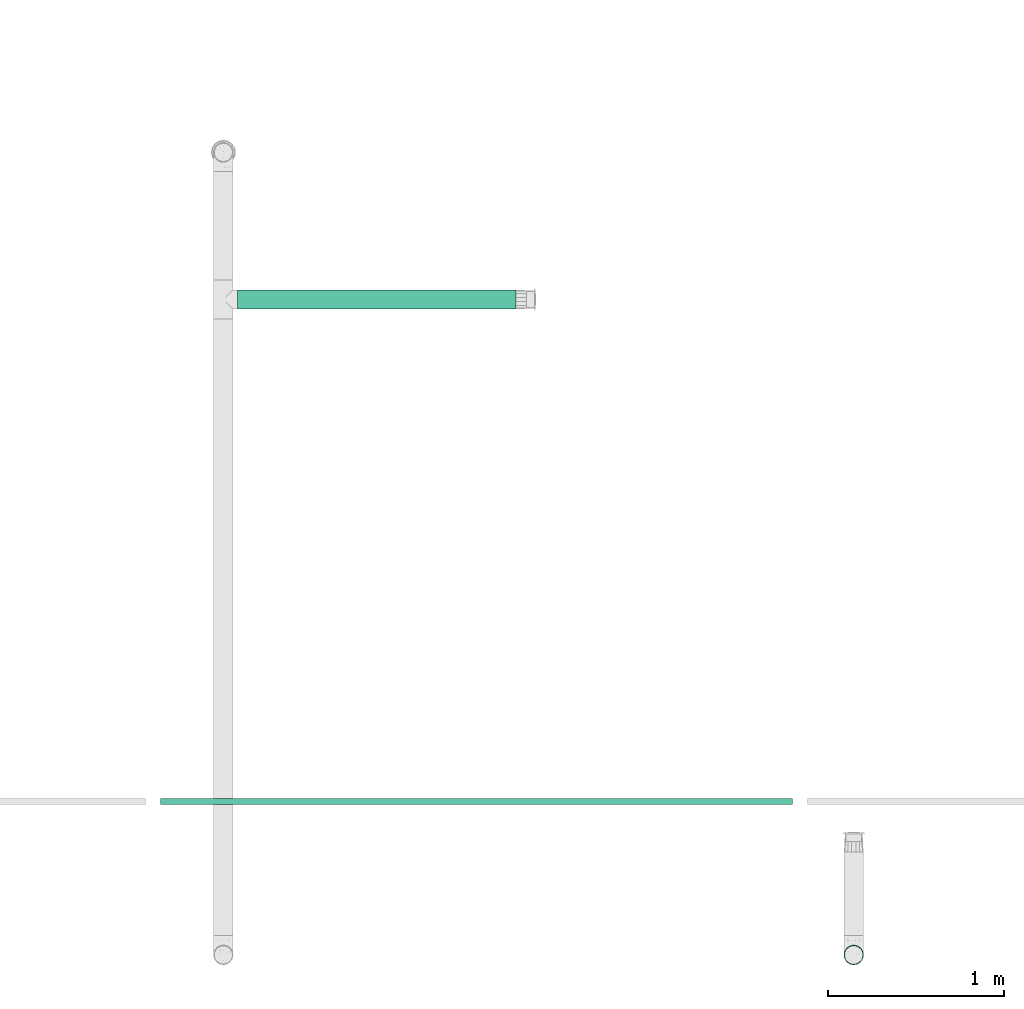
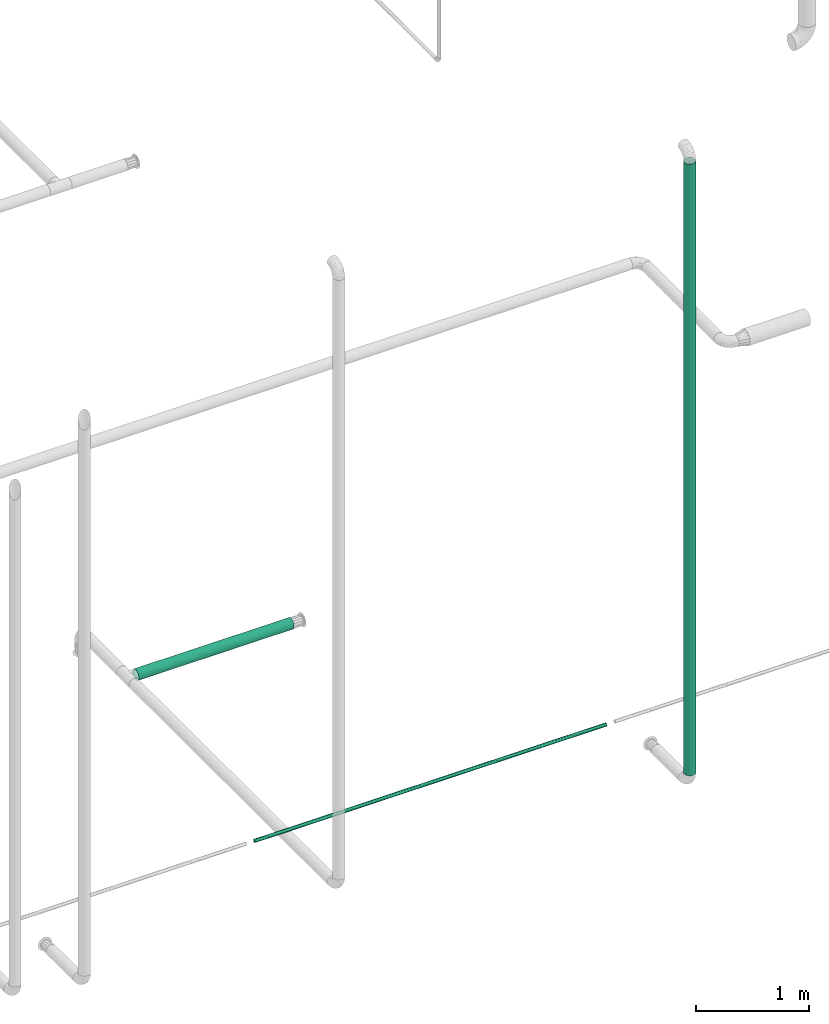
# One storey, part 15 of 123: 3 flow segments.
"""IFC2X3 building model written with IfcOpenShell, lengths in millimetres."""

from ifc_helpers import new_model, entity, si_unit, converted_unit, derived_unit, direction, frame, origin_with_axes, origin_2d_with_axis, place, context, subcontext, project, spatial, hollow_circle, extrude, source, transform, mapped, material, layer, layer_set, layer_usage, type_object, element, save


model = new_model("IFC2X3")

# Units and contexts
model_context = context("Model", 3, precision=1e-05, world=origin_with_axes(), true_north=direction((0.0, 1.0)))
body_context = subcontext(model_context, "Body", "Model", "MODEL_VIEW")
ifc_project = project(units=[si_unit("AREAUNIT", "SQUARE_METRE"), si_unit("VOLUMEUNIT", "CUBIC_METRE", prefix="DECI"), si_unit("TIMEUNIT", "SECOND"), si_unit("THERMODYNAMICTEMPERATUREUNIT", "DEGREE_CELSIUS"), si_unit("PRESSUREUNIT", "PASCAL"), si_unit("MASSUNIT", "GRAM", prefix="KILO"), si_unit("LENGTHUNIT", "METRE", prefix="MILLI"), si_unit("POWERUNIT", "WATT"), si_unit("ELECTRICCURRENTUNIT", "AMPERE"), si_unit("ELECTRICVOLTAGEUNIT", "VOLT"), derived_unit("VOLUMETRICFLOWRATEUNIT", [(si_unit("VOLUMEUNIT", "CUBIC_METRE", prefix="DECI"), 1), (si_unit("TIMEUNIT", "SECOND"), -1)]), derived_unit("LINEARVELOCITYUNIT", [(si_unit("LENGTHUNIT", "METRE"), 1), (si_unit("TIMEUNIT", "SECOND"), -1)]), derived_unit("MASSDENSITYUNIT", [(si_unit("MASSUNIT", "GRAM", prefix="KILO"), 1), (si_unit("VOLUMEUNIT", "CUBIC_METRE"), -1)]), converted_unit("PLANEANGLEUNIT", "DEGREE", entity("IfcRatioMeasure", 0.01745), si_unit("PLANEANGLEUNIT", "RADIAN"), dimensions=[0, 0, 0, 0, 0, 0, 0])], contexts=[model_context])

# Site, building, storey
site_placement = place(None, origin_with_axes())
site = spatial("IfcSite", under=ifc_project, at=site_placement, CompositionType="ELEMENT")
building_placement = place(site_placement, origin_with_axes())
building = spatial("IfcBuilding", under=site, at=building_placement, Name="mc-building", CompositionType="ELEMENT")
storey_placement = place(building_placement, origin_with_axes())
storey = spatial("IfcBuildingStorey", under=building, at=storey_placement, Name="1. Korrus", CompositionType="ELEMENT", Elevation=0.0)

# Flow segments
ifc_material_1 = material(Name="FZ1")
ifc_layer_1 = layer(ifc_material_1, 0.0)
ifc_layer_set_1 = layer_set([ifc_layer_1], Name="FZ1")
ifc_layer_usage_1 = layer_usage(ifc_layer_set_1, "AXIS1", "POSITIVE", 0.0)
duct_segment_type_1 = type_object("IfcDuctSegmentType", Name="Safe", PredefinedType="RIGIDSEGMENT")
shared_shape_1 = source(origin_with_axes(), body_context, "Body", "SweptSolid", [
    extrude(hollow_circle(Radius=55.0, WallThickness=2.0, at=origin_2d_with_axis()), frame((0.0, 0.0, 0.0), z_axis=(1.0, 0.0, 0.0), x_axis=(0.0, 1.0, 0.0)), (0.0, 0.0, 1.0), 6595.0),
])
flow_segment_1_placement = place(storey_placement, frame((33368.54901, -687.64676, 2410.0), z_axis=(0.0, 1.0, 0.0), x_axis=(0.0, 0.0, 1.0)))
element("IfcFlowSegment", 1, at=flow_segment_1_placement, inside=storey, type_object=duct_segment_type_1, material=ifc_layer_usage_1, Name="Safe", context=body_context, shape_type="MappedRepresentation", body=[
    mapped(shared_shape_1, transform((0.0, 0.0, 0.0), scale=1.0)),
])
duct_segment_type_2 = type_object("IfcDuctSegmentType", PredefinedType="RIGIDSEGMENT")
shared_shape_2 = source(origin_with_axes(), body_context, "Body", "SweptSolid", [
    extrude(hollow_circle(Radius=55.0, WallThickness=2.0, at=origin_2d_with_axis()), frame((0.0, 0.0, 0.0), z_axis=(1.0, 0.0, 0.0), x_axis=(0.0, 1.0, 0.0)), (0.0, 0.0, 1.0), 1582.8),
])
flow_segment_2_placement = place(storey_placement, frame((29868.00747, 3035.40319, 2430.0), z_axis=(0.0, 0.0, 1.0), x_axis=(1.0, 0.0, 0.0)))
element("IfcFlowSegment", 2, at=flow_segment_2_placement, inside=storey, type_object=duct_segment_type_2, material=ifc_layer_usage_1, context=body_context, shape_type="MappedRepresentation", body=[
    mapped(shared_shape_2, transform((0.0, 0.0, 0.0), scale=1.0)),
])
ifc_material_2 = material(Name="Steel")
ifc_layer_2 = layer(ifc_material_2, 0.0)
ifc_layer_set_2 = layer_set([ifc_layer_2], Name="Steel")
ifc_layer_usage_2 = layer_usage(ifc_layer_set_2, "AXIS1", "POSITIVE", 0.0)
pipe_segment_type = type_object("IfcPipeSegmentType", PredefinedType="RIGIDSEGMENT")
shared_shape_3 = source(origin_with_axes(), body_context, "Body", "SweptSolid", [
    extrude(hollow_circle(Radius=17.5, WallThickness=2.0, at=origin_2d_with_axis()), frame((0.0, 0.0, 0.0), z_axis=(1.0, 0.0, 0.0), x_axis=(0.0, 1.0, 0.0)), (0.0, 0.0, 1.0), 3590.0),
])
flow_segment_3_placement = place(storey_placement, frame((29431.33832, 185.02869, 2518.78858), z_axis=(0.0, 0.0, 1.0), x_axis=(1.0, 0.0, 0.0)))
element("IfcFlowSegment", 3, at=flow_segment_3_placement, inside=storey, type_object=pipe_segment_type, material=ifc_layer_usage_2, context=body_context, shape_type="MappedRepresentation", body=[
    mapped(shared_shape_3, transform((0.0, 0.0, 0.0), scale=1.0)),
])

save(model, "model.ifc")
